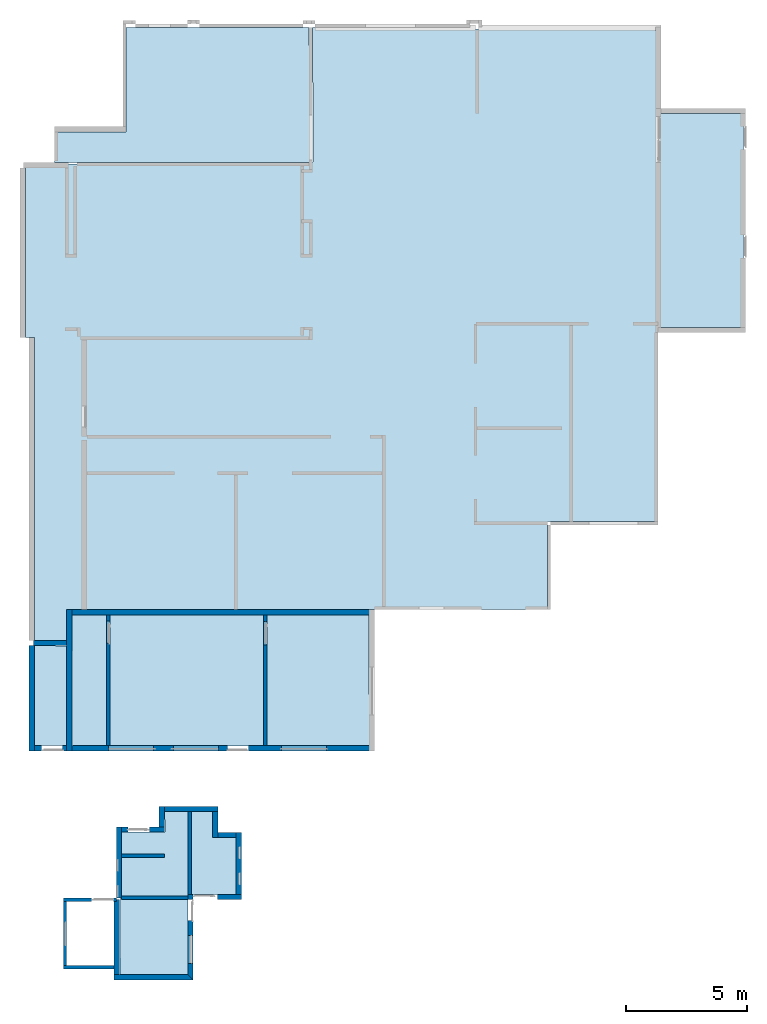
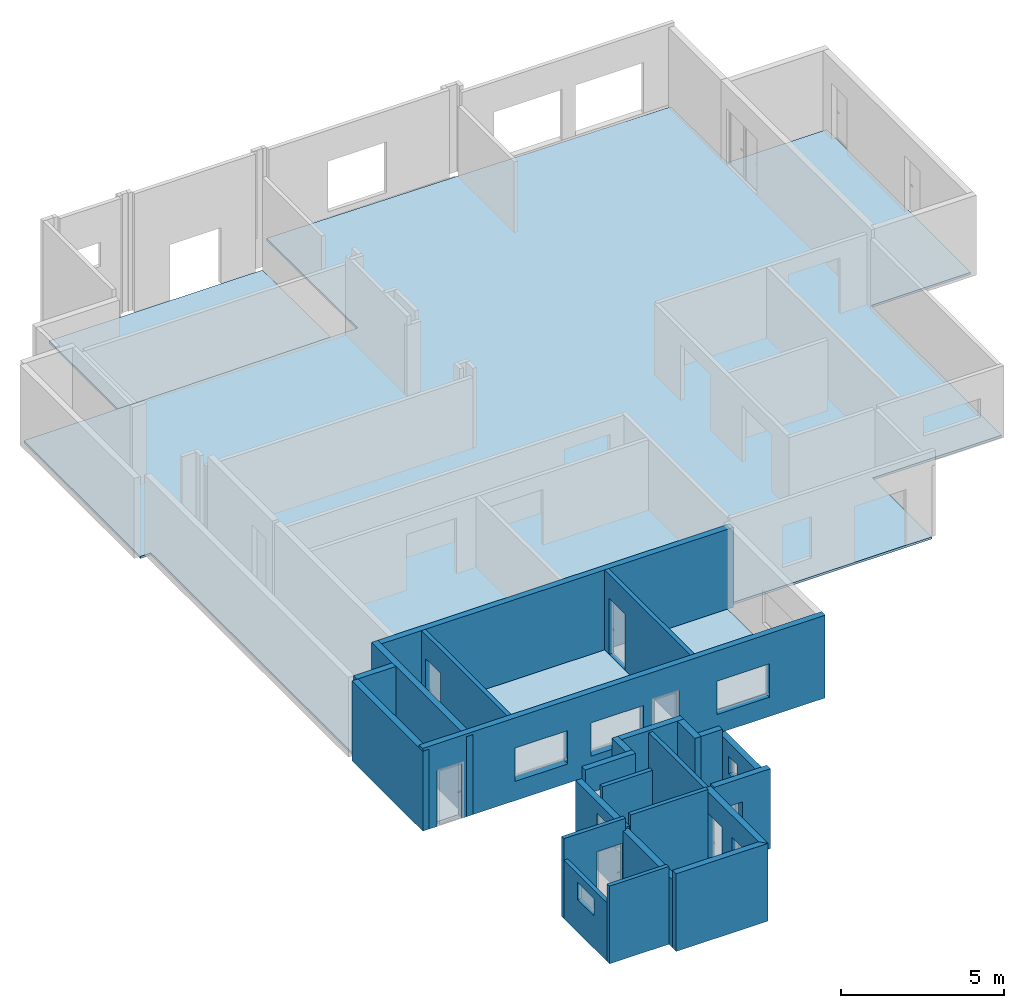
# One storey, part 1 of 4: 24 walls, 5 slabs, 17 openings.
"""IFC4X3_ADD2 building model written with IfcOpenShell, lengths in millimetres."""

from ifc_helpers import new_model, entity, si_unit, converted_unit, frame, origin_with_axes, origin_2d_with_axis, place, context, subcontext, project, spatial, line, indexed_curve, outline, extrude, material, layer, layer_set, layer_usage, type_object, element, save


model = new_model("IFC4X3_ADD2")

# Units and contexts
model_context = context("Model", 3, precision=1e-05, world=origin_with_axes())
plan_context = context("Plan", 2, precision=1e-05, world=origin_2d_with_axis())
body_context = subcontext(model_context, "Body", "Model", "MODEL_VIEW")
ifc_project = project(units=[si_unit("VOLUMEUNIT", "CUBIC_METRE"), si_unit("LENGTHUNIT", "METRE", prefix="MILLI"), converted_unit("PLANEANGLEUNIT", "degree", entity("IfcReal", 0.0174532925199433), si_unit("PLANEANGLEUNIT", "RADIAN"), dimensions=[0, 0, 0, 0, 0, 0, 0]), si_unit("AREAUNIT", "SQUARE_METRE")], contexts=[model_context, plan_context])

# Site, building, storey
site_placement = place(None, origin_with_axes())
site = spatial("IfcSite", under=ifc_project, at=site_placement)
building_placement = place(site_placement, origin_with_axes())
building = spatial("IfcBuilding", under=site, at=building_placement, Name="Building")
storey_placement = place(building_placement, origin_with_axes())
storey = spatial("IfcBuildingStorey", under=building, at=storey_placement, Name="Storey")

# Slabs
ifc_material_1 = material(Name="25 MPa wooden float", Category="Concrete")
ifc_layer_1 = layer(ifc_material_1, 85.0)
ifc_layer_set_1 = layer_set([ifc_layer_1], Name="concrete")
ifc_layer_usage_1 = layer_usage(ifc_layer_set_1, "AXIS3", "POSITIVE", -85.0)
slab_type = type_object("IfcSlabType", Name="85mm surface bed", PredefinedType="BASESLAB", material=ifc_layer_set_1)
slab_1_placement = place(storey_placement, frame((4671.80347442627, 39630.7563781738, 0.0), z_axis=(0.0, 0.0, 1.0), x_axis=(1.0, 0.0, 0.0)))
element("IfcSlab", 1, at=slab_1_placement, inside=storey, type_object=slab_type, material=ifc_layer_usage_1, Name="Slab", context=body_context, shape_type="SweptSolid", body=[
    extrude(outline(indexed_curve([(7445.25439453125, -221.00065612793), (7480.58154296875, -5813.9990234375), (-3084.48388671875, -5813.9912109375), (-3084.484375, -4540.00830078125), (-124.485961914062, -4539.99658203125), (-133.644088745117, -221.008285522461), (7445.25439453125, -221.00065612793)])), frame((0.0, 0.0, -85.0), z_axis=(0.0, 0.0, 1.0), x_axis=(1.0, 0.0, 0.0)), (0.0, 0.0, 1.0), 85.0),
])
ifc_layer_usage_2 = layer_usage(ifc_layer_set_1, "AXIS3", "POSITIVE", -85.0)
slab_2_placement = place(storey_placement, frame((12527.904510498, 39440.2046203613, 1145.0001001358), z_axis=(0.0, 0.0, 1.0), x_axis=(1.0, 0.0, 0.0)))
element("IfcSlab", 2, at=slab_2_placement, inside=storey, type_object=slab_type, material=ifc_layer_usage_2, Name="Slab", context=body_context, shape_type="SweptSolid", body=[
    extrude(outline(indexed_curve([(9443.4130859375, -24117.41796875), (-10439.7822265625, -24117.423828125), (-10439.7841796875, -25387.4375), (-11779.5908203125, -25387.443359375), (-11779.640625, -12863.4453125), (-12153.7763671875, -12863.4462890625), (-12153.7939453125, -5693.48828125), (-247.66081237793, -5598.57470703125), (-270.836242675781, -30.4336528778076), (14028.396484375, -145.500152587891), (14028.4013671875, -3597.42309570312), (17568.40234375, -3597.41918945312), (17568.4140625, -12437.412109375), (14028.4111328125, -12449.1064453125), (14028.4111328125, -20477.41796875), (9443.4111328125, -20477.421875), (9443.4130859375, -24117.41796875)])), frame((0.0, 0.0, -85.0), z_axis=(0.0, 0.0, 1.0), x_axis=(1.0, 0.0, 0.0)), (0.0, 0.0, 1.0), 85.0),
])
ifc_layer_usage_3 = layer_usage(ifc_layer_set_1, "AXIS3", "POSITIVE", -85.0)
slab_3_placement = place(storey_placement, frame((8229.70867156982, 7008.98838043213, 1170.00007629395), z_axis=(0.0, 0.0, 1.0), x_axis=(1.0, 0.0, 0.0)))
element("IfcSlab", 3, at=slab_3_placement, inside=storey, type_object=slab_type, material=ifc_layer_usage_3, Name="Slab", context=body_context, shape_type="SweptSolid", body=[
    extrude(outline(indexed_curve([(-1129.13745117188, -3461.98901367188), (870.862426757812, -3461.98852539062), (872.138916015625, -1115.98864746094), (-112.414352416992, -1115.98889160156), (-112.413879394531, -42.9873428344727), (-2094.4140625, -42.9887733459473), (-2073.89282226562, -894.987548828125), (-3899.201171875, -894.988952636719), (-3931.53369140625, -6788.98876953125), (-1130.41345214844, -6788.98876953125), (-1129.13745117188, -3461.98901367188)])), frame((0.0, 0.0, -85.0), z_axis=(0.0, 0.0, 1.0), x_axis=(1.0, 0.0, 0.0)), (0.0, 0.0, 1.0), 85.0),
])
ifc_layer_usage_4 = layer_usage(ifc_layer_set_1, "AXIS3", "POSITIVE", -85.0)
slab_4_placement = place(storey_placement, frame((2336.74907684326, 9671.92363739014, 1145.0001001358), z_axis=(0.0, 0.0, 1.0), x_axis=(1.0, 0.0, 0.0)))
element("IfcSlab", 4, at=slab_4_placement, inside=storey, type_object=slab_type, material=ifc_layer_usage_4, Name="Slab", context=body_context, shape_type="SweptSolid", body=[
    extrude(outline(indexed_curve([(12272.5732421875, 27.8505077362061), (12259.5693359375, 5430.8505859375), (-28.6283473968506, 5430.84326171875), (0.0, 0.0), (12272.5732421875, 27.8505077362061)])), frame((0.0, 0.0, -85.0), z_axis=(0.0, 0.0, 1.0), x_axis=(1.0, 0.0, 0.0)), (0.0, 0.0, 1.0), 85.0),
])
ifc_layer_usage_5 = layer_usage(ifc_layer_set_1, "AXIS3", "POSITIVE", -85.0)
slab_5_placement = place(storey_placement, frame((748.318672180176, 13832.7531814575, 1145.0001001358), z_axis=(0.0, 0.0, 1.0), x_axis=(1.0, 0.0, 0.0)))
element("IfcSlab", 5, at=slab_5_placement, inside=storey, type_object=slab_type, material=ifc_layer_usage_5, Name="Slab", context=body_context, shape_type="SweptSolid", body=[
    extrude(outline(indexed_curve([(-27.5239925384521, -4135.87060546875), (1324.90051269531, -4132.98388671875), (1339.80261230469, -4.99153089523315), (0.0, 0.0), (-27.5239925384521, -4135.87060546875)])), frame((0.0, 0.0, -85.0), z_axis=(0.0, 0.0, 1.0), x_axis=(1.0, 0.0, 0.0)), (0.0, 0.0, 1.0), 85.0),
])

# Wall
ifc_material_2 = material(Name="Clay_Brick_Red", Category="Bricks")
ifc_layer_2 = layer(ifc_material_2, 220.000015258789)
ifc_layer_set_2 = layer_set([ifc_layer_2])
ifc_layer_usage_6 = layer_usage(ifc_layer_set_2, "AXIS2", "POSITIVE", 0.0)
wall_type_1 = type_object("IfcWallType", Name="220mm_External", PredefinedType="STANDARD", material=ifc_layer_set_2)
wall_1_placement = place(storey_placement, frame((7099.29466247559, 219.999328255653, 1145.0001001358), z_axis=(0.0, 0.0, 1.0), x_axis=(-0.999999999999989, 1.50995802528085e-07, 0.0)))
element("IfcWall", 6, at=wall_1_placement, inside=storey, type_object=wall_type_1, material=ifc_layer_usage_6, Name="Wall", context=body_context, shape_type="SweptSolid", body=[
    extrude(outline(indexed_curve([(0.0, 0.0), (-220.000116434393, 220.000015258789), (3049.00130678693, 220.000015258789), (3049.00130678693, 0.0)], segments=[line(1, 2, 3, 4, 1)])), origin_with_axes(), (0.0, 0.0, 1.0), 2918.00022125244),
])

# Wall, opening
ifc_layer_usage_7 = layer_usage(ifc_layer_set_2, "AXIS2", "POSITIVE", 0.0)
wall_2_placement = place(storey_placement, frame((7319.29397583008, 3326.99966430664, 1145.0001001358), z_axis=(0.0, 0.0, 1.0), x_axis=(0.999999999999993, 1.1920928955078e-07, 0.0)))
wall_2 = element("IfcWall", 7, at=wall_2_placement, inside=storey, type_object=wall_type_1, material=ifc_layer_usage_7, Name="Wall", context=body_context, shape_type="SweptSolid", body=[
    extrude(outline(indexed_curve([(0.0, 0.0), (0.0, 220.000015258789), (1998.0001449585, 220.000015258789), (1998.0001449585, 0.0)], segments=[line(1, 2, 3, 4, 1)])), origin_with_axes(), (0.0, 0.0, 1.0), 3000.0),
])
opening_1_placement = place(wall_2_placement, frame((-2.38418369491455e-05, -199.999809265134, 3.10862446895044e-12), z_axis=(0.0, 0.0, 1.0), x_axis=(0.999999999999993, -1.1920928955078e-07, 0.0)))
element("IfcOpeningElement", 8, at=opening_1_placement, cuts=wall_2, PredefinedType="OPENING", context=body_context, shape_type="SweptSolid", body=[
    extrude(outline(indexed_curve([(0.0, 0.0), (998.999938964844, 0.0), (998.999938964844, 499.999908447266), (0.0, 499.999908447266), (0.0, 0.0)])), origin_with_axes(), (0.0, 0.0, 1.0), 2100.00024414062),
])

# Wall, openings
ifc_layer_usage_8 = layer_usage(ifc_layer_set_2, "AXIS2", "POSITIVE", 0.0)
wall_3_placement = place(storey_placement, frame((9317.29412078857, 3326.99966430664, 1145.0001001358), z_axis=(0.0, 0.0, 1.0), x_axis=(-1.62920684942944e-07, 0.999999999999987, 0.0)))
wall_3 = element("IfcWall", 9, at=wall_3_placement, inside=storey, type_object=wall_type_1, material=ifc_layer_usage_8, Name="Wall", context=body_context, shape_type="SweptSolid", body=[
    extrude(outline(indexed_curve([(0.0, 0.0), (0.0, 220.000015258789), (2786.00001335144, 220.000015258789), (2786.00001335144, 0.0)], segments=[line(1, 2, 3, 4, 1)])), origin_with_axes(), (0.0, 0.0, 1.0), 2733.00004005432),
])
opening_2_placement = place(wall_3_placement, frame((622.000274459961, 349.999803295858, 1556.00011348725), z_axis=(0.0, 0.0, 1.0), x_axis=(-1.62920684942944e-07, -0.999999999999987, 0.0)))
element("IfcOpeningElement", 10, at=opening_2_placement, cuts=wall_3, PredefinedType="OPENING", context=body_context, shape_type="SweptSolid", body=[
    extrude(outline(indexed_curve([(0.0, -22.0000705718994), (499.999908447266, -22.0000705718994), (499.999908447266, 499.999908447266), (0.0, 499.999908447266), (0.0, -22.0000705718994)])), origin_with_axes(), (0.0, 0.0, 1.0), 654.000061035156),
])
opening_3_placement = place(wall_3_placement, frame((1700.00010470592, 349.999627667387, 1556.00011348725), z_axis=(0.0, 0.0, 1.0), x_axis=(-1.62920684942944e-07, -0.999999999999987, 0.0)))
element("IfcOpeningElement", 11, at=opening_3_placement, cuts=wall_3, PredefinedType="OPENING", context=body_context, shape_type="SweptSolid", body=[
    extrude(outline(indexed_curve([(0.0, -22.0000705718994), (499.999908447266, -22.0000705718994), (499.999908447266, 499.999908447266), (0.0, 499.999908447266), (0.0, -22.0000705718994)])), origin_with_axes(), (0.0, 0.0, 1.0), 654.000061035156),
])

# Walls
ifc_layer_usage_9 = layer_usage(ifc_layer_set_2, "AXIS2", "POSITIVE", 0.0)
wall_4_placement = place(storey_placement, frame((9317.29316711426, 6112.99991607666, 1145.0001001358), z_axis=(0.0, 0.0, 1.0), x_axis=(-0.999999999999924, -3.89414367418765e-07, 0.0)))
element("IfcWall", 12, at=wall_4_placement, inside=storey, type_object=wall_type_1, material=ifc_layer_usage_9, Name="Wall", context=body_context, shape_type="SweptSolid", body=[
    extrude(outline(indexed_curve([(220.000015258795, 0.0), (220.000065087408, 220.000015258789), (979.999716497977, 220.000015258789), (979.999716497977, 0.0)], segments=[line(1, 2, 3, 4, 1)])), origin_with_axes(), (0.0, 0.0, 1.0), 3000.0),
])
ifc_layer_usage_10 = layer_usage(ifc_layer_set_2, "AXIS2", "POSITIVE", 0.0)
wall_5_placement = place(storey_placement, frame((8117.29431152344, 6965.99960327148, 1145.0001001358), z_axis=(0.0, 0.0, 1.0), x_axis=(6.71544341912371e-07, -0.999999999999775, 0.0)))
element("IfcWall", 13, at=wall_5_placement, inside=storey, type_object=wall_type_1, material=ifc_layer_usage_10, Name="Wall", context=body_context, shape_type="SweptSolid", body=[
    extrude(outline(indexed_curve([(0.0, 0.0), (0.0, 220.000015258789), (1073.00007343292, 220.000015258789), (1073.00007343292, 0.0)], segments=[line(1, 2, 3, 4, 1)])), origin_with_axes(), (0.0, 0.0, 1.0), 3000.0),
])
ifc_layer_usage_11 = layer_usage(ifc_layer_set_2, "AXIS2", "POSITIVE", 0.0)
wall_6_placement = place(storey_placement, frame((5915.2946472168, 6965.99960327148, 1145.0001001358), z_axis=(0.0, 0.0, 1.0), x_axis=(0.999999999999822, 5.960464477538e-07, 0.0)))
element("IfcWall", 14, at=wall_6_placement, inside=storey, type_object=wall_type_1, material=ifc_layer_usage_11, Name="Wall", context=body_context, shape_type="SweptSolid", body=[
    extrude(outline(indexed_curve([(220.000015258858, 0.0), (219.999841293034, 220.000015258789), (2421.99958918755, 220.000015258789), (2421.99958918755, 0.0)], segments=[line(1, 2, 3, 4, 1)])), origin_with_axes(), (0.0, 0.0, 1.0), 3000.0),
])

# Wall, openings
ifc_layer_usage_12 = layer_usage(ifc_layer_set_2, "AXIS2", "POSITIVE", 0.0)
wall_7_placement = place(storey_placement, frame((4357.29503631592, 3394.00005340576, 1145.00033855438), z_axis=(0.0, 0.0, 1.0), x_axis=(-6.39757843145941e-07, 0.999999999999795, 0.0)))
wall_7 = element("IfcWall", 15, at=wall_7_placement, inside=storey, type_object=wall_type_1, material=ifc_layer_usage_12, Name="Wall", context=body_context, shape_type="SweptSolid", body=[
    extrude(outline(indexed_curve([(0.0, 0.0), (0.0, 220.000015258789), (2940.00005722046, 220.000015258789), (2940.00005722046, 0.0)], segments=[line(1, 2, 3, 4, 1)])), origin_with_axes(), (0.0, 0.0, 1.0), 2549.00002479553),
])
opening_4_placement = place(wall_7_placement, frame((1059.05902940142, 195.000924631572, 1469.27034854889), z_axis=(0.0, 0.0, 1.0), x_axis=(-6.39757843145941e-07, -0.999999999999795, 0.0)))
element("IfcOpeningElement", 16, at=opening_4_placement, cuts=wall_7, PredefinedType="OPENING", context=body_context, shape_type="SweptSolid", body=[
    extrude(outline(indexed_curve([(-123.537048339844, 40.9407539367676), (281.751556396484, 40.9407539367676), (281.751556396484, 562.940490722656), (-123.537048339844, 562.940490722656), (-123.537048339844, 40.9407539367676)])), origin_with_axes(), (0.0, 0.0, 1.0), 654.000061035156),
])
opening_5_placement = place(wall_7_placement, frame((-40.9406368123477, 195.001628364984, 1469.27034854889), z_axis=(0.0, 0.0, 1.0), x_axis=(-6.39757843145941e-07, -0.999999999999795, 0.0)))
element("IfcOpeningElement", 17, at=opening_5_placement, cuts=wall_7, PredefinedType="OPENING", context=body_context, shape_type="SweptSolid", body=[
    extrude(outline(indexed_curve([(-123.537048339844, 40.9407539367676), (281.751556396484, 40.9407539367676), (281.751556396484, 562.940490722656), (-123.537048339844, 562.940490722656), (-123.537048339844, 40.9407539367676)])), origin_with_axes(), (0.0, 0.0, 1.0), 654.000061035156),
])

# Wall, opening
ifc_layer_usage_13 = layer_usage(ifc_layer_set_2, "AXIS2", "POSITIVE", 0.0)
wall_8_placement = place(storey_placement, frame((6135.29396057129, 6334.00058746338, 1145.00033855438), z_axis=(0.0, 0.0, 1.0), x_axis=(-0.999999999999625, -8.66251525621595e-07, 0.0)))
wall_8 = element("IfcWall", 18, at=wall_8_placement, inside=storey, type_object=wall_type_1, material=ifc_layer_usage_13, Name="Wall", context=body_context, shape_type="SweptSolid", body=[
    extrude(outline(indexed_curve([(0.0, 0.0), (0.0, 220.000015258789), (1778.00133180938, 220.000015258789), (1778.00128198076, 0.0)], segments=[line(1, 2, 3, 4, 1)])), origin_with_axes(), (0.0, 0.0, 1.0), 3000.0),
])
opening_6_placement = place(wall_8_placement, frame((1521.00159883462, 299.999826839337, -1145.00033855438), z_axis=(0.0, 0.0, 1.0), x_axis=(-0.999999999999625, 8.66251525621595e-07, 0.0)))
element("IfcOpeningElement", 19, at=opening_6_placement, cuts=wall_8, PredefinedType="OPENING", context=body_context, shape_type="SweptSolid", body=[
    extrude(outline(indexed_curve([(0.0, 499.999816894531), (894.999389648438, 499.999816894531), (894.999389648438, 0.0), (0.0, 0.0), (0.0, 499.999816894531)])), frame((0.0, 0.0, 1120.00012397766), z_axis=(0.0, 0.0, 1.0), x_axis=(1.0, 0.0, 0.0)), (0.0, 0.0, 1.0), 2100.00024414062),
])

# Wall
ifc_layer_usage_14 = layer_usage(ifc_layer_set_2, "AXIS2", "POSITIVE", 0.0)
wall_9_placement = place(storey_placement, frame((5915.2946472168, 7185.99987030029, 1145.00033855438), z_axis=(0.0, 0.0, 1.0), x_axis=(1.5060094256097e-06, -0.999999999998866, 0.0)))
element("IfcWall", 20, at=wall_9_placement, inside=storey, type_object=wall_type_1, material=ifc_layer_usage_14, Name="Wall", context=body_context, shape_type="SweptSolid", body=[
    extrude(outline(indexed_curve([(0.0, 0.0), (0.0, 220.000015258789), (851.999084869832, 220.000015258789), (851.998996575175, 0.0)], segments=[line(1, 2, 3, 4, 1)])), origin_with_axes(), (0.0, 0.0, 1.0), 3000.0),
])

# Wall, openings
ifc_layer_usage_15 = layer_usage(ifc_layer_set_2, "AXIS2", "POSITIVE", 0.0)
wall_10_placement = place(storey_placement, frame((14816.3223266602, 9699.77474212646, 1145.0001001358), z_axis=(0.0, 0.0, 1.0), x_axis=(-0.999999999999924, -3.89414367418765e-07, 0.0)))
wall_10 = element("IfcWall", 21, at=wall_10_placement, inside=storey, type_object=wall_type_1, material=ifc_layer_usage_15, Name="Wall", context=body_context, shape_type="SweptSolid", body=[
    extrude(outline(indexed_curve([(0.0, 0.0), (0.0, 220.000015258789), (14288.0010604858, 220.000015258789), (14288.0010604858, 0.0)], segments=[line(1, 2, 3, 4, 1)])), origin_with_axes(), (0.0, 0.0, 1.0), 3107.00011253357),
])
opening_7_placement = place(wall_10_placement, frame((13400.0003041234, 229.949501390834, -6.46889209747004), z_axis=(0.0, 0.0, 1.0), x_axis=(-0.999999999999924, 3.89414367418765e-07, 0.0)))
element("IfcOpeningElement", 22, at=opening_7_placement, cuts=wall_10, PredefinedType="OPENING", context=body_context, shape_type="SweptSolid", body=[
    extrude(outline(indexed_curve([(-374.999938964844, 0.0), (499.999908447266, 0.0), (499.999908447266, 499.999908447266), (-374.999938964844, 499.999908447266), (-374.999938964844, 0.0)])), origin_with_axes(), (0.0, 0.0, 1.0), 2100.00024414062),
])
opening_8_placement = place(wall_10_placement, frame((3841.0004041982, 219.998771288084, 3.10862446895044e-12), z_axis=(0.0, 0.0, 1.0), x_axis=(-0.999999999999924, 3.89414367418765e-07, 0.0)))
element("IfcOpeningElement", 23, at=opening_8_placement, cuts=wall_10, PredefinedType="OPENING", context=body_context, shape_type="SweptSolid", body=[
    extrude(outline(indexed_curve([(0.0, 0.0), (1864.99987792969, 0.0), (1864.99987792969, 499.999908447266), (0.0, 499.999908447266), (0.0, 0.0)])), frame((0.0, 0.0, 721.531391143799), z_axis=(0.0, 0.0, 1.0), x_axis=(1.0, 0.0, 0.0)), (0.0, 0.0, 1.0), 1252.00012207031),
])
opening_9_placement = place(wall_10_placement, frame((11010.0009105987, 219.995979576288, 3.10862446895044e-12), z_axis=(0.0, 0.0, 1.0), x_axis=(-0.999999999999924, 3.89414367418765e-07, 0.0)))
element("IfcOpeningElement", 24, at=opening_9_placement, cuts=wall_10, PredefinedType="OPENING", context=body_context, shape_type="SweptSolid", body=[
    extrude(outline(indexed_curve([(0.0, 0.0), (1864.99987792969, 0.0), (1864.99987792969, 499.999908447266), (0.0, 499.999908447266), (0.0, 0.0)])), frame((0.0, 0.0, 721.531391143799), z_axis=(0.0, 0.0, 1.0), x_axis=(1.0, 0.0, 0.0)), (0.0, 0.0, 1.0), 1252.00012207031),
])
opening_10_placement = place(wall_10_placement, frame((8320.0003765413, 219.997027101144, 3.10862446895044e-12), z_axis=(0.0, 0.0, 1.0), x_axis=(-0.999999999999924, 3.89414367418765e-07, 0.0)))
element("IfcOpeningElement", 25, at=opening_10_placement, cuts=wall_10, PredefinedType="OPENING", context=body_context, shape_type="SweptSolid", body=[
    extrude(outline(indexed_curve([(0.0, 0.0), (1864.99987792969, 0.0), (1864.99987792969, 499.999908447266), (0.0, 499.999908447266), (0.0, 0.0)])), frame((0.0, 0.0, 721.531391143799), z_axis=(0.0, 0.0, 1.0), x_axis=(1.0, 0.0, 0.0)), (0.0, 0.0, 1.0), 1252.00012207031),
])
opening_11_placement = place(wall_10_placement, frame((5698.00040139874, 229.952500660254, -6.46889209747004), z_axis=(0.0, 0.0, 1.0), x_axis=(-0.999999999999924, 3.89414367418765e-07, 0.0)))
element("IfcOpeningElement", 26, at=opening_11_placement, cuts=wall_10, PredefinedType="OPENING", context=body_context, shape_type="SweptSolid", body=[
    extrude(outline(indexed_curve([(-374.999938964844, 0.0), (499.999908447266, 0.0), (499.999908447266, 499.999908447266), (-374.999938964844, 499.999908447266), (-374.999938964844, 0.0)])), origin_with_axes(), (0.0, 0.0, 1.0), 2100.00024414062),
])

# Walls
ifc_layer_usage_16 = layer_usage(ifc_layer_set_2, "AXIS2", "POSITIVE", 0.0)
wall_11_placement = place(storey_placement, frame((714.119911193848, 13832.7531814575, 1145.0001001358), z_axis=(0.0, 0.0, 1.0), x_axis=(0.999999999990273, 4.410743713336e-06, 0.0)))
element("IfcWall", 27, at=wall_11_placement, inside=storey, type_object=wall_type_1, material=ifc_layer_usage_16, Name="Wall", context=body_context, shape_type="SweptSolid", body=[
    extrude(outline(indexed_curve([(0.0, 0.0), (0.0, 220.000015258789), (1374.00007247925, 220.000015258789), (1374.00007247925, 0.0)], segments=[line(1, 2, 3, 4, 1)])), origin_with_axes(), (0.0, 0.0, 1.0), 3000.0),
])
ifc_layer_usage_17 = layer_usage(ifc_layer_set_2, "AXIS2", "POSITIVE", 0.0)
wall_12_placement = place(storey_placement, frame((528.318405151367, 13832.7531814575, 1145.0001001358), z_axis=(0.0, 0.0, 1.0), x_axis=(6.71544341912371e-07, -0.999999999999775, 0.0)))
element("IfcWall", 28, at=wall_12_placement, inside=storey, type_object=wall_type_1, material=ifc_layer_usage_17, Name="Wall", context=body_context, shape_type="SweptSolid", body=[
    extrude(outline(indexed_curve([(0.0, 0.0), (-0.000848849964313558, 220.000015258789), (4352.97884051055, 220.000015258789), (4352.97884051055, 0.0)], segments=[line(1, 2, 3, 4, 1)])), origin_with_axes(), (0.0, 0.0, 1.0), 3000.0),
])
ifc_layer_usage_18 = layer_usage(ifc_layer_set_2, "AXIS2", "POSITIVE", 0.0)
wall_13_placement = place(storey_placement, frame((2088.12060825467, 15102.7669906617, 1145.0001001358), z_axis=(0.0, 0.0, 1.0), x_axis=(0.999999999999822, 5.960464477538e-07, 0.0)))
element("IfcWall", 29, at=wall_13_placement, inside=storey, type_object=wall_type_1, material=ifc_layer_usage_18, Name="Wall", context=body_context, shape_type="SweptSolid", body=[
    extrude(outline(indexed_curve([(220.00001525879, 0.0), (219.999998649252, 220.000015258789), (12716.2434746356, 220.000015258789), (12716.2434746356, 0.0)], segments=[line(1, 2, 3, 4, 1)])), origin_with_axes(), (0.0, 0.0, 1.0), 3000.0),
])
ifc_layer_usage_19 = layer_usage(ifc_layer_set_2, "AXIS2", "POSITIVE", 0.0)
wall_14_placement = place(storey_placement, frame((2088.12046051025, 15322.7739334106, 1145.0001001358), z_axis=(0.0, 0.0, 1.0), x_axis=(6.71544341912371e-07, -0.999999999999775, 0.0)))
element("IfcWall", 30, at=wall_14_placement, inside=storey, type_object=wall_type_1, material=ifc_layer_usage_19, Name="Wall", context=body_context, shape_type="SweptSolid", body=[
    extrude(outline(indexed_curve([(0.0, 0.0), (0.0, 220.000015258789), (5843.0004119873, 220.000015258789), (5843.0004119873, 0.0)], segments=[line(1, 2, 3, 4, 1)])), origin_with_axes(), (0.0, 0.0, 1.0), 3000.0),
])
ifc_layer_usage_20 = layer_usage(ifc_layer_set_2, "AXIS2", "NEGATIVE", 0.0)
wall_15_placement = place(storey_placement, frame((4270.29323577881, 3326.99966430664, 1145.0001001358), z_axis=(0.0, 0.0, 1.0), x_axis=(3.13916473260163e-07, -0.999999999999951, 0.0)))
element("IfcWall", 31, at=wall_15_placement, inside=storey, type_object=wall_type_1, material=ifc_layer_usage_20, Name="Wall", context=body_context, shape_type="SweptSolid", body=[
    extrude(outline(indexed_curve([(-4.28355833719252e-05, -220.000015258789), (0.0, 0.0), (3106.99988019473, 0.0), (3106.99988019473, -220.000015258789)], segments=[line(1, 2, 3, 4, 1)])), origin_with_axes(), (0.0, 0.0, 1.0), 2549.00002479553),
])

# Wall, openings
ifc_layer_usage_21 = layer_usage(ifc_layer_set_2, "AXIS2", "POSITIVE", 0.0)
wall_16_placement = place(storey_placement, frame((7099.29466247559, 3547.00040817261, 1145.0001001358), z_axis=(0.0, 0.0, 1.0), x_axis=(3.13916473260163e-07, -0.999999999999951, 0.0)))
wall_16 = element("IfcWall", 32, at=wall_16_placement, inside=storey, type_object=wall_type_1, material=ifc_layer_usage_21, Name="Wall", context=body_context, shape_type="SweptSolid", body=[
    extrude(outline(indexed_curve([(0.0, 0.0), (0.0, 220.000015258789), (3547.00107423428, 220.000015258789), (3327.00095669476, 0.0)], segments=[line(1, 2, 3, 4, 1)])), origin_with_axes(), (0.0, 0.0, 1.0), 2918.00022125244),
])
opening_12_placement = place(wall_16_placement, frame((2867.00128904927, 220.000304819255, 1143.7703371048), z_axis=(0.0, 0.0, 1.0), x_axis=(3.13916473260163e-07, 0.999999999999951, 0.0)))
element("IfcOpeningElement", 33, at=opening_12_placement, cuts=wall_16, PredefinedType="OPENING", context=body_context, shape_type="SweptSolid", body=[
    extrude(outline(indexed_curve([(-370.000793457031, 0.0), (129.999130249023, 0.0), (129.999130249023, 1159.0), (-370.000793457031, 1159.0), (-370.000793457031, 0.0)])), origin_with_axes(), (0.0, 0.0, 1.0), 957.0),
])
opening_13_placement = place(wall_16_placement, frame((1095.00047266463, -149.999978153915, 3.10862446895044e-12), z_axis=(0.0, 0.0, 1.0), x_axis=(3.13916473260163e-07, 0.999999999999951, 0.0)))
element("IfcOpeningElement", 34, at=opening_13_placement, cuts=wall_16, PredefinedType="OPENING", context=body_context, shape_type="SweptSolid", body=[
    extrude(outline(indexed_curve([(0.0, 0.0), (499.999908447266, 0.0), (499.999908447266, 875.000122070312), (0.0, 875.000122070312), (0.0, 0.0)])), origin_with_axes(), (0.0, 0.0, 1.0), 2100.00024414062),
])

# Wall
ifc_material_3 = material(Category="Plastic")
ifc_layer_3 = layer(ifc_material_3, 140.0)
ifc_layer_set_3 = layer_set([ifc_layer_3])
ifc_layer_usage_22 = layer_usage(ifc_layer_set_3, "AXIS2", "POSITIVE", 0.0)
wall_type_2 = type_object("IfcWallType", Name="RDP", PredefinedType="ELEMENTEDWALL", material=ifc_layer_set_3)
wall_17_placement = place(storey_placement, frame((4050.29392242432, 590.000152587891, 1145.0001001358), z_axis=(0.0, 0.0, 1.0), x_axis=(-0.999999999999924, -3.89414367418765e-07, 0.0)))
element("IfcWall", 35, at=wall_17_placement, inside=storey, type_object=wall_type_2, material=ifc_layer_usage_22, Name="Wall", context=body_context, shape_type="SweptSolid", body=[
    extrude(outline(indexed_curve([(0.0, 0.0), (0.0, 140.0), (2106.00018501282, 140.0), (2106.00018501282, 0.0)], segments=[line(1, 2, 3, 4, 1)])), origin_with_axes(), (0.0, 0.0, 1.0), 2918.00022125244),
])

# Wall, opening
ifc_layer_usage_23 = layer_usage(ifc_layer_set_3, "AXIS2", "POSITIVE", 0.0)
wall_18_placement = place(storey_placement, frame((1944.29302215576, 3253.99875640869, 1145.0001001358), z_axis=(0.0, 0.0, 1.0), x_axis=(6.71544341912371e-07, -0.999999999999775, 0.0)))
wall_18 = element("IfcWall", 36, at=wall_18_placement, inside=storey, type_object=wall_type_2, material=ifc_layer_usage_23, Name="Wall", context=body_context, shape_type="SweptSolid", body=[
    extrude(outline(indexed_curve([(0.0, 0.0), (1.05697051822062e-05, 140.0), (2803.99990081788, 140.0), (2803.99990081788, 0.0)], segments=[line(1, 2, 3, 4, 1)])), origin_with_axes(), (0.0, 0.0, 1.0), 2193.00007820129),
])
opening_14_placement = place(wall_18_placement, frame((1821.9996019199, -100.001699039712, 1222.00000286103), z_axis=(0.0, 0.0, 1.0), x_axis=(6.71544341912371e-07, 0.999999999999775, 0.0)))
element("IfcOpeningElement", 37, at=opening_14_placement, cuts=wall_18, PredefinedType="OPENING", context=body_context, shape_type="SweptSolid", body=[
    extrude(outline(indexed_curve([(0.0, -31.0000114440918), (499.999847412109, -31.0000114440918), (499.999847412109, 981.999755859375), (0.0, 981.999755859375), (0.0, -31.0000114440918)])), origin_with_axes(), (0.0, 0.0, 1.0), 654.000061035156),
])

ifc_layer_usage_24 = layer_usage(ifc_layer_set_3, "AXIS2", "POSITIVE", 0.0)
wall_19_placement = place(storey_placement, frame((1944.29302215576, 3253.99875640869, 1145.00033855438), z_axis=(0.0, 0.0, 1.0), x_axis=(0.999999999999822, 5.960464477538e-07, 0.0)))
wall_19 = element("IfcWall", 38, at=wall_19_placement, inside=storey, type_object=wall_type_2, material=ifc_layer_usage_24, Name="Wall", context=body_context, shape_type="SweptSolid", body=[
    extrude(outline(indexed_curve([(0.0, 0.0), (0.0, 140.0), (2193.00007820129, 140.0), (2193.00007820129, 0.0)], segments=[line(1, 2, 3, 4, 1)])), origin_with_axes(), (0.0, 0.0, 1.0), 3000.0),
])
opening_15_placement = place(wall_19_placement, frame((1585.99942326524, -110.000840425165, 2.22044604925031e-12), z_axis=(0.0, 0.0, 1.0), x_axis=(0.999999999999822, -5.960464477538e-07, 0.0)))
element("IfcOpeningElement", 39, at=opening_15_placement, cuts=wall_19, PredefinedType="OPENING", context=body_context, shape_type="SweptSolid", body=[
    extrude(outline(indexed_curve([(-413.000061035156, 0.0), (499.999908447266, 0.0), (499.999908447266, 499.999908447266), (-413.000061035156, 499.999908447266), (-413.000061035156, 0.0)])), origin_with_axes(), (0.0, 0.0, 1.0), 2100.00024414062),
])

# Walls
ifc_material_4 = material(Name="PVA", Category="Paint")
ifc_layer_4 = layer(ifc_material_4, 2.0, ventilated=False, Name="2_PVA_paint_primer")
ifc_layer_5 = layer(ifc_material_4, 1.0, ventilated=False, Name="1st_coat_paint_primer")
ifc_layer_6 = layer(ifc_material_1, 15.0000009536743, ventilated=False, Name="Plaster15mm")
ifc_material_5 = material(Name="NFX-Clay", Category="Clay Bricks")
ifc_layer_7 = layer(ifc_material_5, 110.000007629395, Name="NFP_110bricks")
ifc_layer_8 = layer(ifc_material_1, 15.0000009536743, ventilated=False, Name="Plaster15mm")
ifc_layer_9 = layer(ifc_material_4, 1.0, ventilated=False, Name="1st_coat_paint_primer")
ifc_layer_10 = layer(ifc_material_4, 2.0, ventilated=False, Name="2_PVA_paint_primer")
ifc_layer_set_4 = layer_set([ifc_layer_4, ifc_layer_5, ifc_layer_6, ifc_layer_7, ifc_layer_8, ifc_layer_9, ifc_layer_10], Name="Internal_plaster_painted_wall")
ifc_layer_usage_25 = layer_usage(ifc_layer_set_4, "AXIS2", "POSITIVE", 0.0)
wall_type_3 = type_object("IfcWallType", Name="Internal110", PredefinedType="STANDARD", material=ifc_layer_set_4)
wall_20_placement = place(storey_placement, frame((7099.29275512695, 6966.00008010864, 1145.0001001358), z_axis=(0.0, 0.0, 1.0), x_axis=(3.13916473260163e-07, -0.999999999999951, 0.0)))
element("IfcWall", 40, at=wall_20_placement, inside=storey, type_object=wall_type_3, material=ifc_layer_usage_25, Name="Wall", context=body_context, shape_type="SweptSolid", body=[
    extrude(outline(indexed_curve([(0.0, 0.0), (-4.11909789666778e-05, 146.000009536744), (3419.00092249643, 146.000009536744), (3419.00089406918, 0.0)], segments=[line(1, 2, 3, 4, 1)])), origin_with_axes(), (0.0, 0.0, 1.0), 2918.00022125244),
])
ifc_layer_usage_26 = layer_usage(ifc_layer_set_4, "AXIS2", "POSITIVE", 0.0)
wall_21_placement = place(storey_placement, frame((6135.29586791992, 5212.60643005371, 1145.00033855438), z_axis=(0.0, 0.0, 1.0), x_axis=(-0.999999999999625, -8.66251525621595e-07, 0.0)))
element("IfcWall", 41, at=wall_21_placement, inside=storey, type_object=wall_type_3, material=ifc_layer_usage_26, Name="Wall", context=body_context, shape_type="SweptSolid", body=[
    extrude(outline(indexed_curve([(0.0, 0.0), (0.0, 146.000009536744), (1778.00128198076, 146.000009536744), (1778.00128198076, 0.0)], segments=[line(1, 2, 3, 4, 1)])), origin_with_axes(), (0.0, 0.0, 1.0), 3000.0),
])
ifc_layer_usage_27 = layer_usage(ifc_layer_set_4, "AXIS2", "POSITIVE", 0.0)
wall_22_placement = place(storey_placement, frame((4357.29503631592, 3326.99966430664, 1145.0001001358), z_axis=(0.0, 0.0, 1.0), x_axis=(0.999999999999993, 1.1920928955078e-07, 0.0)))
element("IfcWall", 42, at=wall_22_placement, inside=storey, type_object=wall_type_3, material=ifc_layer_usage_27, Name="Wall", context=body_context, shape_type="SweptSolid", body=[
    extrude(outline(indexed_curve([(0.0, 0.0), (0.0, 146.000009536744), (2741.99920517143, 146.000009536744), (2741.9992342692, 0.0)], segments=[line(1, 2, 3, 4, 1)])), origin_with_axes(), (0.0, 0.0, 1.0), 3000.0),
])

# Wall, opening
ifc_layer_usage_28 = layer_usage(ifc_layer_set_4, "AXIS2", "POSITIVE", 0.0)
wall_23_placement = place(storey_placement, frame((10229.9960230202, 15102.7718435976, 1145.0001001358), z_axis=(0.0, 0.0, 1.0), x_axis=(6.71544341912371e-07, -0.999999999999775, 0.0)))
wall_23 = element("IfcWall", 43, at=wall_23_placement, inside=storey, type_object=wall_type_3, material=ifc_layer_usage_28, Name="Wall", context=body_context, shape_type="SweptSolid", body=[
    extrude(outline(indexed_curve([(0.0, 0.0), (1.1022693229279e-05, 146.000009536744), (5402.99805514535, 146.000009536744), (5402.99805514535, 0.0)], segments=[line(1, 2, 3, 4, 1)])), origin_with_axes(), (0.0, 0.0, 1.0), 3000.0),
])
opening_16_placement = place(wall_23_placement, frame((1251.14341314796, -189.000311704808, 0.167250633239746), z_axis=(0.0, 0.0, 1.0), x_axis=(6.71544341912371e-07, 0.999999999999774, 0.0)))
element("IfcOpeningElement", 44, at=opening_16_placement, cuts=wall_23, PredefinedType="OPENING", context=body_context, shape_type="SweptSolid", body=[
    extrude(outline(indexed_curve([(0.0, 972.314758300781), (499.999938964844, 972.314758300781), (499.999938964844, 0.0), (0.0, 0.0), (0.0, 972.314758300781)])), origin_with_axes(), (0.0, 0.0, 1.0), 2100.00024414062),
])

ifc_layer_usage_29 = layer_usage(ifc_layer_set_4, "AXIS2", "POSITIVE", 0.0)
wall_24_placement = place(storey_placement, frame((3729.99602302276, 15102.7679692957, 1145.0001001358), z_axis=(0.0, 0.0, 1.0), x_axis=(6.71544341912371e-07, -0.999999999999775, 0.0)))
wall_24 = element("IfcWall", 45, at=wall_24_placement, inside=storey, type_object=wall_type_3, material=ifc_layer_usage_29, Name="Wall", context=body_context, shape_type="SweptSolid", body=[
    extrude(outline(indexed_curve([(0.0, 0.0), (1.10226932861224e-05, 146.000009536744), (5402.99418084344, 146.000009536744), (5402.99418084344, 0.0)], segments=[line(1, 2, 3, 4, 1)])), origin_with_axes(), (0.0, 0.0, 1.0), 3000.0),
])
opening_17_placement = place(wall_24_placement, frame((874.310350543313, -249.999690529025, 0.167250633239746), z_axis=(0.0, 0.0, 1.0), x_axis=(6.71544341912371e-07, 0.999999999999774, 0.0)))
element("IfcOpeningElement", 46, at=opening_17_placement, cuts=wall_24, PredefinedType="OPENING", context=body_context, shape_type="SweptSolid", body=[
    extrude(outline(indexed_curve([(0.0, -292.222015380859), (499.999908447266, -292.222015380859), (499.999908447266, 632.778076171875), (0.0, 632.778076171875), (0.0, -292.222015380859)])), origin_with_axes(), (0.0, 0.0, 1.0), 2100.00024414062),
])

save(model, "model.ifc")
